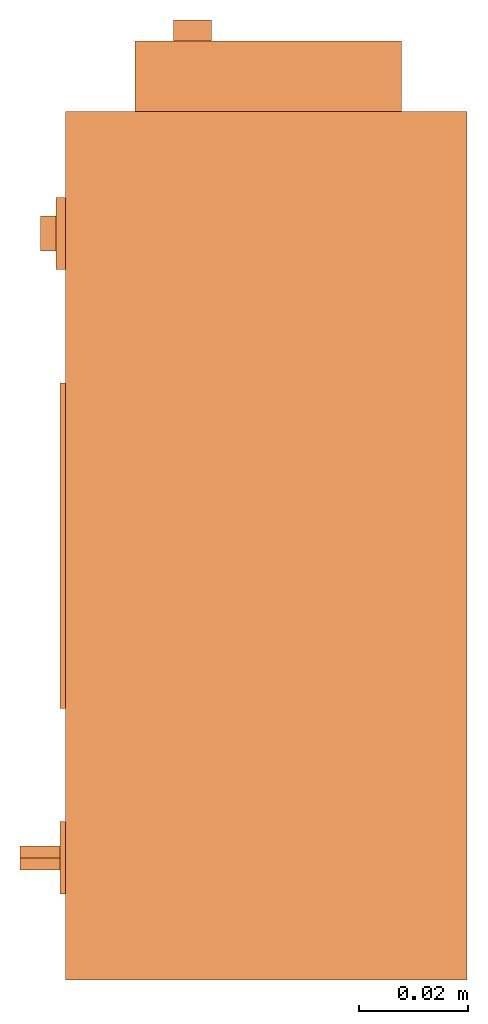
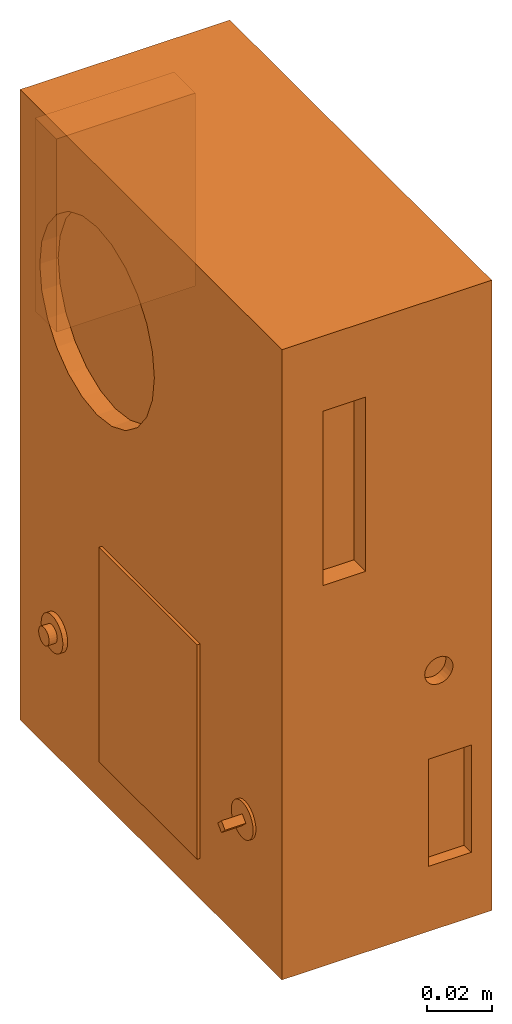
# One storey: 2 proxies.
"""IFC2X3 building model written with IfcOpenShell, lengths in millimetres."""

from ifc_helpers import new_model, entity, si_unit, converted_unit, derived_unit, direction, frame, origin, place, context, subcontext, project, spatial, faceted_brep, source, transform, mapped, material, material_list, type_object, type_shapes, element, save


model = new_model("IFC2X3")

# Units and contexts
model_context = context("Model", 3, precision=0.01, world=origin(), true_north=direction((6.12303176911189e-17, 1.0)))
body_context = subcontext(model_context, "Body", "Model", "MODEL_VIEW")
ifc_project = project(units=[si_unit("LENGTHUNIT", "METRE", prefix="MILLI"), si_unit("AREAUNIT", "SQUARE_METRE"), si_unit("VOLUMEUNIT", "CUBIC_METRE"), converted_unit("PLANEANGLEUNIT", "DEGREE", entity("IfcRatioMeasure", 0.0174532925199433), si_unit("PLANEANGLEUNIT", "RADIAN"), dimensions=[0, 0, 0, 0, 0, 0, 0]), si_unit("MASSUNIT", "GRAM", prefix="KILO"), derived_unit("MASSDENSITYUNIT", [(si_unit("MASSUNIT", "GRAM", prefix="KILO"), 1), (si_unit("LENGTHUNIT", "METRE"), -3)]), derived_unit("MOMENTOFINERTIAUNIT", [(si_unit("LENGTHUNIT", "METRE"), 4)]), si_unit("TIMEUNIT", "SECOND"), si_unit("FREQUENCYUNIT", "HERTZ"), si_unit("THERMODYNAMICTEMPERATUREUNIT", "DEGREE_CELSIUS"), derived_unit("THERMALTRANSMITTANCEUNIT", [(si_unit("MASSUNIT", "GRAM", prefix="KILO"), 1), (si_unit("THERMODYNAMICTEMPERATUREUNIT", "KELVIN"), -1), (si_unit("TIMEUNIT", "SECOND"), -3)]), derived_unit("VOLUMETRICFLOWRATEUNIT", [(si_unit("LENGTHUNIT", "METRE"), 3), (si_unit("TIMEUNIT", "SECOND"), -1)]), derived_unit("MASSFLOWRATEUNIT", [(si_unit("MASSUNIT", "GRAM", prefix="KILO"), 1), (si_unit("TIMEUNIT", "SECOND"), -1)]), derived_unit("ROTATIONALFREQUENCYUNIT", [(si_unit("TIMEUNIT", "SECOND"), -1)]), si_unit("ELECTRICCURRENTUNIT", "AMPERE"), si_unit("ELECTRICVOLTAGEUNIT", "VOLT"), si_unit("POWERUNIT", "WATT"), si_unit("FORCEUNIT", "NEWTON", prefix="KILO"), si_unit("ILLUMINANCEUNIT", "LUX"), si_unit("LUMINOUSFLUXUNIT", "LUMEN"), si_unit("LUMINOUSINTENSITYUNIT", "CANDELA"), derived_unit("USERDEFINED", [(si_unit("MASSUNIT", "GRAM", prefix="KILO"), -1), (si_unit("LENGTHUNIT", "METRE"), -2), (si_unit("TIMEUNIT", "SECOND"), 3), (si_unit("LUMINOUSFLUXUNIT", "LUMEN"), 1)]), derived_unit("LINEARVELOCITYUNIT", [(si_unit("LENGTHUNIT", "METRE"), 1), (si_unit("TIMEUNIT", "SECOND"), -1)]), si_unit("PRESSUREUNIT", "PASCAL"), derived_unit("USERDEFINED", [(si_unit("LENGTHUNIT", "METRE"), -2), (si_unit("MASSUNIT", "GRAM", prefix="KILO"), 1), (si_unit("TIMEUNIT", "SECOND"), -2)]), derived_unit("LINEARFORCEUNIT", [(si_unit("MASSUNIT", "GRAM", prefix="KILO"), 1), (si_unit("LENGTHUNIT", "METRE"), 1), (si_unit("TIMEUNIT", "SECOND"), -2), (si_unit("LENGTHUNIT", "METRE"), -1)]), derived_unit("PLANARFORCEUNIT", [(si_unit("MASSUNIT", "GRAM", prefix="KILO"), 1), (si_unit("LENGTHUNIT", "METRE"), 1), (si_unit("TIMEUNIT", "SECOND"), -2), (si_unit("LENGTHUNIT", "METRE"), -2)])], contexts=[model_context])

# Site, building, storey
site_placement = place(None, frame((0.0, 2493.83037508239, 0.0)))
site = spatial("IfcSite", under=ifc_project, at=site_placement, CompositionType="ELEMENT")
building_placement = place(site_placement, origin())
building = spatial("IfcBuilding", under=site, at=building_placement, CompositionType="ELEMENT")
storey_placement = place(building_placement, frame((0.0, 0.0, 4200.0)))
storey = spatial("IfcBuildingStorey", under=building, at=storey_placement, CompositionType="ELEMENT", Elevation=4200.0)

# Proxies
ifc_material_1 = material()
ifc_material_2 = material()
ifc_material_list_1 = material_list([ifc_material_1, ifc_material_2])
building_element_proxy_type_1 = type_object("IfcBuildingElementProxyType", PredefinedType="NOTDEFINED", material=ifc_material_1)
shared_shape_1 = source(origin(), body_context, "Body", "Brep", [
    faceted_brep([(-82.3504485835914, -57.4951122884829, 44.240131361728), (-82.3504485835914, -59.713005625247, 46.4580246984921), (-82.3504485835914, -57.4951122884829, 48.6759180352563), (-82.3504485835914, -55.2772189517187, 46.4580246984921), (-74.0, -55.2772189517187, 46.4580246984921), (-74.0, -57.4951122884829, 48.6759180352563), (-74.0, -59.713005625247, 46.4580246984921), (-74.0, -57.4951122884829, 44.240131361728)], [[[0, 1, 2, 3]], [[4, 5, 6, 7]], [[3, 4, 7, 0]], [[7, 6, 1, 0]], [[1, 6, 5, 2]], [[5, 4, 3, 2]]]),
    faceted_brep([(-78.5701040447422, 54.3886959944422, 45.6256629611489), (-78.5701040447422, 54.2791134928247, 46.4580246984921), (-78.5701040447422, 54.3886959944422, 47.2903864358354), (-78.5701040447422, 54.7099756329028, 48.0660240963215), (-78.5701040447422, 55.2210577317854, 48.7320792551901), (-78.5701040447422, 55.8871128906541, 49.2431613540727), (-78.5701040447422, 56.6627505511402, 49.5644409925334), (-78.5701040447422, 57.4951122884834, 49.6740234941508), (-78.5701040447422, 58.3274740258266, 49.5644409925334), (-78.5701040447422, 59.1031116863127, 49.2431613540727), (-78.5701040447422, 59.7691668451814, 48.7320792551902), (-78.5701040447422, 60.280248944064, 48.0660240963215), (-78.5701040447422, 60.6015285825246, 47.2903864358354), (-78.5701040447422, 60.7111110841421, 46.4580246984921), (-78.5701040447422, 60.6015285825247, 45.6256629611489), (-78.5701040447422, 60.280248944064, 44.8500253006628), (-78.5701040447422, 59.7691668451814, 44.1839701417941), (-78.5701040447422, 59.1031116863128, 43.6728880429116), (-78.5701040447422, 58.3274740258267, 43.3516084044509), (-78.5701040447422, 57.4951122884834, 43.2420259028335), (-78.5701040447422, 56.6627505511402, 43.3516084044509), (-78.5701040447422, 55.8871128906541, 43.6728880429116), (-78.5701040447422, 55.2210577317854, 44.1839701417941), (-78.5701040447422, 54.7099756329029, 44.8500253006628), (-74.0, 57.4951122884834, 49.6740234941508), (-74.0, 56.6627505511402, 49.5644409925334), (-74.0, 55.8871128906541, 49.2431613540727), (-74.0, 55.2210577317854, 48.7320792551901), (-74.0, 54.7099756329028, 48.0660240963215), (-74.0, 54.3886959944422, 47.2903864358354), (-74.0, 54.2791134928247, 46.4580246984921), (-74.0, 54.3886959944422, 45.6256629611489), (-74.0, 54.7099756329028, 44.8500253006628), (-74.0, 55.2210577317854, 44.1839701417941), (-74.0, 55.8871128906541, 43.6728880429116), (-74.0, 56.6627505511402, 43.3516084044509), (-74.0, 57.4951122884834, 43.2420259028335), (-74.0, 58.3274740258266, 43.3516084044509), (-74.0, 59.1031116863127, 43.6728880429116), (-74.0, 59.7691668451814, 44.1839701417941), (-74.0, 60.280248944064, 44.8500253006628), (-74.0, 60.6015285825246, 45.6256629611489), (-74.0, 60.7111110841421, 46.4580246984921), (-74.0, 60.6015285825246, 47.2903864358354), (-74.0, 60.280248944064, 48.0660240963215), (-74.0, 59.7691668451814, 48.7320792551902), (-74.0, 59.1031116863127, 49.2431613540727), (-74.0, 58.3274740258266, 49.5644409925334)], [[[0, 1, 2, 3, 4, 5, 6, 7, 8, 9, 10, 11, 12, 13, 14, 15, 16, 17, 18, 19, 20, 21, 22, 23]], [[24, 25, 26, 27, 28, 29, 30, 31, 32, 33, 34, 35, 36, 37, 38, 39, 40, 41, 42, 43, 44, 45, 46, 47]], [[41, 14, 13, 42]], [[40, 15, 14, 41]], [[17, 16, 39, 38]], [[40, 39, 16, 15]], [[18, 17, 38, 37]], [[19, 18, 37, 36]], [[35, 20, 19, 36]], [[34, 21, 20, 35]], [[23, 22, 33, 32]], [[34, 33, 22, 21]], [[0, 23, 32, 31]], [[1, 0, 31, 30]], [[29, 2, 1, 30]], [[28, 3, 2, 29]], [[5, 4, 27, 26]], [[28, 27, 4, 3]], [[6, 5, 26, 25]], [[7, 6, 25, 24]], [[47, 8, 7, 24]], [[46, 9, 8, 47]], [[11, 10, 45, 44]], [[46, 45, 10, 9]], [[12, 11, 44, 43]], [[13, 12, 43, 42]]]),
    faceted_brep([(-75.0, -54.1636284675258, 52.2283239409835), (-75.0, -52.7836826860589, 51.1694543009162), (-75.0, -51.7248130459916, 49.7895085194492), (-75.0, -51.0591797634297, 48.1825276211214), (-75.0, -50.8321446465688, 46.4580246984921), (-75.0, -51.0591797634297, 44.7335217758629), (-75.0, -51.7248130459915, 43.1265408775351), (-75.0, -52.7836826860589, 41.7465950960681), (-75.0, -54.1636284675258, 40.6877254560008), (-75.0, -55.7706093658536, 40.022092173439), (-75.0, -57.4951122884828, 39.7950570565781), (-75.0, -59.219615211112, 40.0220921734389), (-75.0, -60.8265961094399, 40.6877254560008), (-75.0, -62.2065418909068, 41.7465950960681), (-75.0, -63.2654115309741, 43.1265408775351), (-75.0, -63.931044813536, 44.7335217758629), (-75.0, -64.1580799303969, 46.4580246984921), (-75.0, -63.931044813536, 48.1825276211213), (-75.0, -63.2654115309741, 49.7895085194492), (-75.0, -62.2065418909069, 51.1694543009161), (-75.0, -60.8265961094399, 52.2283239409834), (-75.0, -59.2196152111121, 52.8939572235453), (-75.0, -57.4951122884829, 53.1209923404062), (-75.0, -55.7706093658537, 52.8939572235453), (-74.0, -55.7706093658536, 40.022092173439), (-74.0, -54.1636284675258, 40.6877254560008), (-74.0, -52.7836826860589, 41.7465950960681), (-74.0, -51.7248130459915, 43.1265408775351), (-74.0, -51.0591797634297, 44.7335217758629), (-74.0, -50.8321446465688, 46.4580246984922), (-74.0, -51.0591797634297, 48.1825276211214), (-74.0, -51.7248130459916, 49.7895085194492), (-74.0, -52.7836826860589, 51.1694543009162), (-74.0, -54.1636284675258, 52.2283239409835), (-74.0, -55.7706093658537, 52.8939572235453), (-74.0, -57.4951122884829, 53.1209923404062), (-74.0, -59.2196152111121, 52.8939572235453), (-74.0, -60.8265961094399, 52.2283239409834), (-74.0, -62.2065418909069, 51.1694543009161), (-74.0, -63.2654115309741, 49.7895085194492), (-74.0, -63.931044813536, 48.1825276211213), (-74.0, -64.1580799303969, 46.4580246984921), (-74.0, -63.931044813536, 44.7335217758629), (-74.0, -63.2654115309741, 43.1265408775351), (-74.0, -62.2065418909068, 41.7465950960681), (-74.0, -60.8265961094399, 40.6877254560008), (-74.0, -59.219615211112, 40.0220921734389), (-74.0, -57.4951122884828, 39.7950570565781)], [[[0, 1, 2, 3, 4, 5, 6, 7, 8, 9, 10, 11, 12, 13, 14, 15, 16, 17, 18, 19, 20, 21, 22, 23]], [[24, 25, 26, 27, 28, 29, 30, 31, 32, 33, 34, 35, 36, 37, 38, 39, 40, 41, 42, 43, 44, 45, 46, 47]], [[28, 5, 4, 29]], [[27, 6, 5, 28]], [[8, 7, 26, 25]], [[27, 26, 7, 6]], [[9, 8, 25, 24]], [[10, 9, 24, 47]], [[46, 11, 10, 47]], [[45, 12, 11, 46]], [[14, 13, 44, 43]], [[45, 44, 13, 12]], [[15, 14, 43, 42]], [[16, 15, 42, 41]], [[17, 16, 41, 40]], [[39, 18, 17, 40]], [[20, 19, 38, 37]], [[39, 38, 19, 18]], [[37, 36, 21, 20]], [[22, 21, 36, 35]], [[34, 23, 22, 35]], [[33, 0, 23, 34]], [[2, 1, 32, 31]], [[32, 1, 0, 33]], [[30, 3, 2, 31]], [[4, 3, 30, 29]]]),
    faceted_brep([(-75.7053616894587, 54.1636284675264, 40.6877254560008), (-75.7053616894587, 52.7836826860594, 41.7465950960681), (-75.7053616894587, 51.7248130459921, 43.1265408775351), (-75.7053616894587, 51.0591797634302, 44.7335217758629), (-75.7053616894587, 50.8321446465693, 46.4580246984921), (-75.7053616894587, 51.0591797634302, 48.1825276211213), (-75.7053616894587, 51.7248130459921, 49.7895085194492), (-75.7053616894587, 52.7836826860594, 51.1694543009161), (-75.7053616894587, 54.1636284675264, 52.2283239409834), (-75.7053616894587, 55.7706093658542, 52.8939572235453), (-75.7053616894587, 57.4951122884834, 53.1209923404062), (-75.7053616894587, 59.2196152111126, 52.8939572235453), (-75.7053616894587, 60.8265961094404, 52.2283239409834), (-75.7053616894587, 62.2065418909074, 51.1694543009161), (-75.7053616894587, 63.2654115309747, 49.7895085194492), (-75.7053616894587, 63.9310448135366, 48.1825276211214), (-75.7053616894587, 64.1580799303975, 46.4580246984922), (-75.7053616894587, 63.9310448135366, 44.733521775863), (-75.7053616894587, 63.2654115309747, 43.1265408775351), (-75.7053616894587, 62.2065418909074, 41.7465950960682), (-75.7053616894587, 60.8265961094405, 40.6877254560009), (-75.7053616894587, 59.2196152111126, 40.022092173439), (-75.7053616894587, 57.4951122884834, 39.7950570565781), (-75.7053616894587, 55.7706093658542, 40.0220921734389), (-74.0, 55.7706093658542, 52.8939572235453), (-74.0, 54.1636284675264, 52.2283239409834), (-74.0, 52.7836826860594, 51.1694543009161), (-74.0, 51.7248130459921, 49.7895085194492), (-74.0, 51.0591797634302, 48.1825276211213), (-74.0, 50.8321446465693, 46.4580246984921), (-74.0, 51.0591797634302, 44.7335217758629), (-74.0, 51.7248130459921, 43.1265408775351), (-74.0, 52.7836826860594, 41.7465950960681), (-74.0, 54.1636284675264, 40.6877254560008), (-74.0, 55.7706093658542, 40.0220921734389), (-74.0, 57.4951122884834, 39.7950570565781), (-74.0, 59.2196152111126, 40.022092173439), (-74.0, 60.8265961094405, 40.6877254560009), (-74.0, 62.2065418909074, 41.7465950960682), (-74.0, 63.2654115309747, 43.1265408775351), (-74.0, 63.9310448135366, 44.733521775863), (-74.0, 64.1580799303975, 46.4580246984922), (-74.0, 63.9310448135366, 48.1825276211214), (-74.0, 63.2654115309747, 49.7895085194492), (-74.0, 62.2065418909074, 51.1694543009161), (-74.0, 60.8265961094404, 52.2283239409834), (-74.0, 59.2196152111126, 52.8939572235453), (-74.0, 57.4951122884834, 53.1209923404062)], [[[0, 1, 2, 3, 4, 5, 6, 7, 8, 9, 10, 11, 12, 13, 14, 15, 16, 17, 18, 19, 20, 21, 22, 23]], [[24, 25, 26, 27, 28, 29, 30, 31, 32, 33, 34, 35, 36, 37, 38, 39, 40, 41, 42, 43, 44, 45, 46, 47]], [[17, 16, 41, 40]], [[39, 18, 17, 40]], [[20, 19, 38, 37]], [[39, 38, 19, 18]], [[37, 36, 21, 20]], [[22, 21, 36, 35]], [[34, 23, 22, 35]], [[33, 0, 23, 34]], [[2, 1, 32, 31]], [[32, 1, 0, 33]], [[30, 3, 2, 31]], [[4, 3, 30, 29]], [[28, 5, 4, 29]], [[27, 6, 5, 28]], [[8, 7, 26, 25]], [[27, 26, 7, 6]], [[9, 8, 25, 24]], [[10, 9, 24, 47]], [[46, 11, 10, 47]], [[45, 12, 11, 46]], [[14, 13, 44, 43]], [[45, 44, 13, 12]], [[15, 14, 43, 42]], [[16, 15, 42, 41]]]),
    faceted_brep([(-75.0, 30.0, 95.0), (-75.0, 30.0, 15.0), (-75.0, -30.0, 15.0), (-75.0, -30.0, 95.0), (-74.0, 30.0, 95.0), (-74.0, -30.0, 95.0), (-74.0, -30.0, 15.0), (-74.0, 30.0, 15.0)], [[[0, 1, 2, 3]], [[4, 5, 6, 7]], [[1, 0, 4, 7]], [[2, 1, 7, 6]], [[3, 2, 6, 5]], [[0, 3, 5, 4]]]),
    faceted_brep([(0.0, 80.0, 235.0), (-74.0, 80.0, 235.0), (-74.0, -80.0, 235.0), (0.0, -80.0, 235.0), (0.0, -80.0, 0.0), (-74.0, -80.0, 0.0), (-74.0, 80.0, 0.0), (0.0, 80.0, 0.0), (-74.0, 50.4209133185051, 207.548823548156), (-74.0, 41.9795798970934, 211.045338335818), (-74.0, 57.6696506600342, 201.98667175723), (-74.0, 32.9209133185052, 212.237934415701), (-74.0, 63.2318024509604, 194.737934415701), (-74.0, 66.7283172386224, 186.296600994289), (-74.0, 67.920913318505, 177.237934415701), (-74.0, 23.8622467399169, 211.045338335818), (-74.0, 66.7283172386224, 168.179267837113), (-74.0, 63.2318024509604, 159.737934415701), (-74.0, 57.6696506600342, 152.489197074172), (-74.0, 50.4209133185051, 146.927045283246), (-74.0, 41.9795798970933, 143.430530495584), (-74.0, 32.9209133185051, 142.237934415701), (-74.0, 23.8622467399169, 143.430530495584), (-74.0, -0.886490601612379, 168.179267837113), (-74.0, 2.61002418604972, 159.737934415701), (-74.0, 15.4209133185051, 146.927045283246), (-74.0, 8.17217597697594, 152.489197074172), (-74.0, 15.4209133185051, 207.548823548157), (-74.0, 8.17217597697595, 201.98667175723), (-74.0, 2.61002418604972, 194.737934415701), (-74.0, -0.886490601612362, 186.29660099429), (-74.0, -2.07908668149505, 177.237934415701), (-59.4948410559892, -80.0, 207.012326083588), (-44.4948410559892, -80.0, 207.012326083588), (-59.4948410559892, -80.0, 142.012326083588), (-22.2311731201611, -80.0, 64.2388716266812), (-22.2311731201611, -80.0, 24.2388716266812), (-7.23117312016112, -80.0, 24.2388716266812), (-7.23117312016112, -80.0, 64.2388716266812), (-44.4948410559892, -80.0, 142.012326083588), (-16.1594491359494, -80.0, 100.388904415053), (-15.1239152300166, -80.0, 99.5943113020636), (-14.3293221170272, -80.0, 98.5587773961309), (-13.829820004504, -80.0, 97.3528726216434), (-17.3653539104367, -80.0, 91.2291482646855), (-16.1594491359494, -80.0, 91.7286503772087), (-15.1239152300166, -80.0, 92.5232434901981), (-14.3293221170272, -80.0, 93.5587773961309), (-13.829820004504, -80.0, 94.7646821706183), (-13.6594491359494, -80.0, 96.0587773961309), (-18.6594491359493, -80.0, 91.0587773961309), (-19.9535443614619, -80.0, 91.2291482646855), (-21.1594491359493, -80.0, 91.7286503772087), (-22.1949830418821, -80.0, 92.5232434901981), (-22.9895761548716, -80.0, 93.5587773961308), (-23.4890782673947, -80.0, 94.7646821706182), (-23.6594491359494, -80.0, 96.0587773961309), (-23.4890782673947, -80.0, 97.3528726216435), (-22.9895761548716, -80.0, 98.5587773961309), (-22.1949830418821, -80.0, 99.5943113020636), (-21.1594491359493, -80.0, 100.388904415053), (-19.9535443614619, -80.0, 100.888406527576), (-18.6594491359493, -80.0, 101.058777396131), (-17.3653539104367, -80.0, 100.888406527576), (-67.5070892619463, 15.4209133185049, 207.548823548156), (-67.5070892619462, 23.8622467399167, 211.045338335818), (-67.5070892619462, 32.9209133185049, 212.237934415701), (-67.5070892619462, 41.9795798970931, 211.045338335818), (-67.5070892619462, 50.4209133185049, 207.548823548156), (-67.5070892619462, 57.669650660034, 201.98667175723), (-67.5070892619462, 63.2318024509603, 194.737934415701), (-67.5070892619462, 66.7283172386223, 186.296600994289), (-67.5070892619462, 67.9209133185049, 177.237934415701), (-67.5070892619462, 66.7283172386224, 168.179267837113), (-67.5070892619462, 63.2318024509604, 159.737934415701), (-67.5070892619462, 57.6696506600342, 152.489197074172), (-67.5070892619462, 50.4209133185051, 146.927045283246), (-67.5070892619462, 41.9795798970933, 143.430530495584), (-67.5070892619462, 32.9209133185051, 142.237934415701), (-67.5070892619462, 23.8622467399169, 143.430530495584), (-67.5070892619463, 15.4209133185051, 146.927045283246), (-67.5070892619463, 8.17217597697592, 152.489197074172), (-67.5070892619463, 2.61002418604969, 159.737934415701), (-67.5070892619463, -0.886490601612388, 168.179267837113), (-67.5070892619463, -2.07908668149506, 177.237934415701), (-67.5070892619463, -0.886490601612447, 186.296600994289), (-67.5070892619463, 2.61002418604958, 194.737934415701), (-67.5070892619463, 8.17217597697576, 201.98667175723), (-59.4948410559892, -72.8398650075826, 207.012326083588), (-59.4948410559892, -72.8398650075826, 142.012326083588), (-44.4948410559892, -72.8398650075826, 142.012326083588), (-44.4948410559892, -72.8398650075826, 207.012326083588), (-22.2311731201611, -75.6449854904968, 64.2388716266812), (-22.2311731201611, -75.6449854904968, 24.2388716266812), (-7.23117312016111, -75.6449854904968, 24.2388716266812), (-7.23117312016111, -75.6449854904968, 64.2388716266812), (-21.1594491359494, -75.6449854904968, 91.7286503772087), (-19.953544361462, -75.6449854904968, 91.2291482646855), (-18.6594491359494, -75.6449854904968, 91.0587773961309), (-17.3653539104368, -75.6449854904968, 91.2291482646855), (-16.1594491359494, -75.6449854904968, 91.7286503772087), (-15.1239152300166, -75.6449854904968, 92.5232434901981), (-14.3293221170272, -75.6449854904968, 93.5587773961309), (-13.829820004504, -75.6449854904968, 94.7646821706182), (-13.6594491359493, -75.6449854904968, 96.0587773961308), (-13.829820004504, -75.6449854904968, 97.3528726216434), (-14.3293221170271, -75.6449854904968, 98.5587773961309), (-15.1239152300166, -75.6449854904968, 99.5943113020636), (-16.1594491359493, -75.6449854904968, 100.388904415053), (-17.3653539104367, -75.6449854904968, 100.888406527576), (-18.6594491359493, -75.6449854904968, 101.058777396131), (-19.9535443614619, -75.6449854904968, 100.888406527576), (-21.1594491359493, -75.6449854904968, 100.388904415053), (-22.1949830418821, -75.6449854904968, 99.5943113020636), (-22.9895761548715, -75.6449854904968, 98.5587773961309), (-23.4890782673947, -75.6449854904968, 97.3528726216435), (-23.6594491359494, -75.6449854904968, 96.0587773961309), (-23.4890782673947, -75.6449854904968, 94.7646821706183), (-22.9895761548715, -75.6449854904968, 93.5587773961309), (-22.1949830418821, -75.6449854904968, 92.5232434901981)], [[[0, 1, 2, 3]], [[4, 5, 6, 7]], [[1, 8, 9]], [[8, 1, 10]], [[1, 9, 11]], [[12, 10, 1]], [[13, 12, 1]], [[14, 13, 1]], [[1, 6, 14]], [[15, 1, 11]], [[1, 15, 2]], [[16, 14, 6]], [[17, 16, 6]], [[18, 17, 6]], [[6, 19, 18]], [[19, 6, 20]], [[21, 20, 6]], [[6, 22, 21]], [[22, 6, 5]], [[23, 5, 2]], [[23, 24, 5]], [[25, 22, 5]], [[26, 5, 24]], [[5, 26, 25]], [[2, 15, 27]], [[27, 28, 2]], [[28, 29, 2]], [[29, 30, 2]], [[2, 30, 31]], [[23, 2, 31]], [[2, 32, 33]], [[32, 2, 34]], [[2, 5, 34]], [[2, 33, 3]], [[34, 5, 35]], [[35, 5, 36]], [[5, 4, 36]], [[4, 37, 36]], [[38, 37, 4]], [[38, 4, 3]], [[33, 39, 3]], [[39, 40, 3]], [[40, 41, 3]], [[41, 42, 3]], [[42, 43, 3]], [[3, 43, 38]], [[38, 44, 35]], [[45, 44, 38]], [[45, 38, 46]], [[47, 46, 38]], [[47, 38, 48]], [[49, 48, 38]], [[49, 38, 43]], [[44, 50, 35]], [[35, 50, 51]], [[35, 51, 52]], [[52, 53, 35]], [[54, 35, 53]], [[54, 55, 35]], [[34, 55, 56]], [[55, 34, 35]], [[57, 34, 56]], [[57, 58, 34]], [[58, 59, 39]], [[58, 39, 34]], [[60, 39, 59]], [[39, 60, 61]], [[39, 61, 62]], [[63, 39, 62]], [[39, 63, 40]], [[0, 3, 4, 7]], [[1, 0, 7, 6]], [[64, 65, 66, 67, 68, 69, 70, 71, 72, 73, 74, 75, 76, 77, 78, 79, 80, 81, 82, 83, 84, 85, 86, 87]], [[72, 14, 16, 73]], [[73, 16, 17, 74]], [[76, 75, 18, 19]], [[18, 75, 74, 17]], [[77, 76, 19, 20]], [[77, 20, 21, 78]], [[78, 21, 22, 79]], [[79, 22, 25, 80]], [[82, 81, 26, 24]], [[26, 81, 80, 25]], [[83, 82, 24, 23]], [[83, 23, 31, 84]], [[84, 31, 30, 85]], [[85, 30, 29, 86]], [[64, 87, 28, 27]], [[28, 87, 86, 29]], [[65, 64, 27, 15]], [[65, 15, 11, 66]], [[66, 11, 9, 67]], [[67, 9, 8, 68]], [[70, 69, 10, 12]], [[10, 69, 68, 8]], [[71, 70, 12, 13]], [[71, 13, 14, 72]], [[88, 89, 90, 91]], [[88, 32, 34, 89]], [[90, 89, 34, 39]], [[90, 39, 33, 91]], [[91, 33, 32, 88]], [[92, 93, 94, 95]], [[96, 97, 98, 99, 100, 101, 102, 103, 104, 105, 106, 107, 108, 109, 110, 111, 112, 113, 114, 115, 116, 117, 118, 119]], [[92, 35, 36, 93]], [[93, 36, 37, 94]], [[94, 37, 38, 95]], [[95, 38, 35, 92]], [[104, 49, 43, 105]], [[105, 43, 42, 106]], [[108, 107, 41, 40]], [[41, 107, 106, 42]], [[109, 108, 40, 63]], [[109, 63, 62, 110]], [[110, 62, 61, 111]], [[111, 61, 60, 112]], [[114, 113, 59, 58]], [[59, 113, 112, 60]], [[115, 114, 58, 57]], [[115, 57, 56, 116]], [[116, 56, 55, 117]], [[117, 55, 54, 118]], [[96, 119, 53, 52]], [[53, 119, 118, 54]], [[97, 96, 52, 51]], [[97, 51, 50, 98]], [[98, 50, 44, 99]], [[99, 44, 45, 100]], [[102, 101, 46, 47]], [[46, 101, 100, 45]], [[103, 102, 47, 48]], [[103, 48, 49, 104]]]),
])
type_shapes(building_element_proxy_type_1, [shared_shape_1])
proxy_1_placement = place(storey_placement, frame((73370.0002685552, 12200.5498524102, 2460.0)))
element("IfcBuildingElementProxy", 1, at=proxy_1_placement, inside=storey, type_object=building_element_proxy_type_1, material=ifc_material_list_1, context=body_context, shape_type="MappedRepresentation", body=[
    mapped(shared_shape_1, transform((0.0, 0.0, 0.0), scale=1.0)),
])
ifc_material_3 = material()
ifc_material_4 = material()
ifc_material_list_2 = material_list([ifc_material_3, ifc_material_4])
building_element_proxy_type_2 = type_object("IfcBuildingElementProxyType", PredefinedType="NOTDEFINED", material=ifc_material_3)
shared_shape_2 = source(origin(), body_context, "Body", "Brep", [
    faceted_brep([(0.0, 9.70151456467493, 9.73834612738113), (0.0, 8.853718255961, 10.0895148565803), (0.0, 8.12569906110286, 10.6481436325617), (0.0, 7.5670702851215, 11.3761628274197), (0.0, 7.21590155592234, 12.2239591361336), (0.0, 7.09612444206653, 13.1337566413141), (0.0, 7.21590155592233, 14.0435541464947), (0.0, 7.56707028512149, 14.8913504552086), (0.0, 8.12569906110284, 15.6193696500666), (0.0, 8.85371825596098, 16.177998426048), (0.0, 9.7015145646749, 16.5291671552471), (0.0, 10.6113120698554, 16.648944269103), (0.0, 11.5211095750359, 16.5291671552471), (0.0, 12.3689058837499, 16.177998426048), (0.0, 13.096925078608, 15.6193696500666), (0.0, 13.6555538545894, 14.8913504552086), (0.0, 14.0067225837885, 14.0435541464947), (0.0, 14.1264996976443, 13.1337566413141), (0.0, 14.0067225837885, 12.2239591361336), (0.0, 13.6555538545894, 11.3761628274197), (0.0, 13.096925078608, 10.6481436325617), (0.0, 12.3689058837499, 10.0895148565803), (0.0, 11.521109575036, 9.73834612738113), (0.0, 10.6113120698554, 9.61856901352529), (3.82281759831273, 9.7015145646749, 16.5291671552471), (3.82281759831273, 8.85371825596097, 16.177998426048), (3.82281759831273, 8.12569906110284, 15.6193696500666), (3.82281759831273, 7.56707028512148, 14.8913504552086), (3.82281759831273, 7.21590155592232, 14.0435541464947), (3.82281759831273, 7.09612444206653, 13.1337566413141), (3.82281759831273, 7.21590155592233, 12.2239591361336), (3.82281759831273, 7.56707028512149, 11.3761628274197), (3.82281759831273, 8.12569906110285, 10.6481436325617), (3.82281759831273, 8.85371825596099, 10.0895148565803), (3.82281759831273, 9.70151456467492, 9.73834612738113), (3.82281759831273, 10.6113120698554, 9.61856901352529), (3.82281759831274, 11.5211095750359, 9.73834612738113), (3.82281759831274, 12.3689058837499, 10.0895148565803), (3.82281759831274, 13.096925078608, 10.6481436325617), (3.82281759831274, 13.6555538545894, 11.3761628274197), (3.82281759831274, 14.0067225837885, 12.2239591361336), (3.82281759831274, 14.1264996976443, 13.1337566413141), (3.82281759831274, 14.0067225837885, 14.0435541464947), (3.82281759831274, 13.6555538545894, 14.8913504552086), (3.82281759831274, 13.096925078608, 15.6193696500666), (3.82281759831274, 12.3689058837499, 16.177998426048), (3.82281759831274, 11.5211095750359, 16.5291671552471), (3.82281759831273, 10.6113120698554, 16.648944269103)], [[[0, 1, 2, 3, 4, 5, 6, 7, 8, 9, 10, 11, 12, 13, 14, 15, 16, 17, 18, 19, 20, 21, 22, 23]], [[24, 25, 26, 27, 28, 29, 30, 31, 32, 33, 34, 35, 36, 37, 38, 39, 40, 41, 42, 43, 44, 45, 46, 47]], [[18, 17, 41, 40]], [[39, 19, 18, 40]], [[21, 20, 38, 37]], [[39, 38, 20, 19]], [[37, 36, 22, 21]], [[23, 22, 36, 35]], [[34, 0, 23, 35]], [[33, 1, 0, 34]], [[3, 2, 32, 31]], [[2, 1, 33, 32]], [[31, 30, 4, 3]], [[5, 4, 30, 29]], [[28, 6, 5, 29]], [[27, 7, 6, 28]], [[9, 8, 26, 25]], [[27, 26, 8, 7]], [[10, 9, 25, 24]], [[11, 10, 24, 47]], [[46, 12, 11, 47]], [[45, 13, 12, 46]], [[15, 14, 44, 43]], [[45, 44, 14, 13]], [[16, 15, 43, 42]], [[17, 16, 42, 41]]]),
    faceted_brep([(16.8239233594376, 49.056494355586, 72.0190470640746), (3.82281759831279, 49.056494355586, 72.0190470640746), (3.82281759831271, 0.0, 72.0190470640746), (16.8239233594376, 0.0, 72.0190470640746), (16.8239233594376, 0.0, 0.0), (3.82281759831271, 0.0, 0.0), (3.82281759831279, 49.056494355586, 0.0), (16.8239233594376, 49.056494355586, 0.0), (3.82281759831277, 38.0970267269559, 16.0375565533757), (3.82281759831278, 41.0008266390171, 13.1337566413144), (3.82281759831277, 38.0970267269559, 10.2299567292531), (3.82281759831277, 35.1932268148946, 13.1337566413144), (8.82281759831278, 41.0008266390171, 13.1337566413144), (8.82281759831278, 38.0970267269559, 10.2299567292531), (8.82281759831277, 35.1932268148946, 13.1337566413144), (8.82281759831278, 38.0970267269559, 16.0375565533757)], [[[0, 1, 2, 3]], [[4, 5, 6, 7]], [[1, 8, 2]], [[8, 1, 9]], [[6, 9, 1]], [[9, 6, 10]], [[5, 10, 6]], [[2, 11, 5]], [[5, 11, 10]], [[11, 2, 8]], [[3, 2, 5, 4]], [[0, 3, 4, 7]], [[1, 0, 7, 6]], [[12, 13, 14, 15]], [[10, 13, 12, 9]], [[11, 14, 13, 10]], [[8, 15, 14, 11]], [[9, 12, 15, 8]]]),
])
type_shapes(building_element_proxy_type_2, [shared_shape_2])
proxy_2_placement = place(storey_placement, frame((73308.8230610644, 12297.3737757697, 2600.0), z_axis=(0.0, 0.0, 1.0), x_axis=(0.0, -1.0, 0.0)))
element("IfcBuildingElementProxy", 2, at=proxy_2_placement, inside=storey, type_object=building_element_proxy_type_2, material=ifc_material_list_2, context=body_context, shape_type="MappedRepresentation", body=[
    mapped(shared_shape_2, transform((0.0, 0.0, 0.0), scale=1.0)),
])

save(model, "model.ifc")
